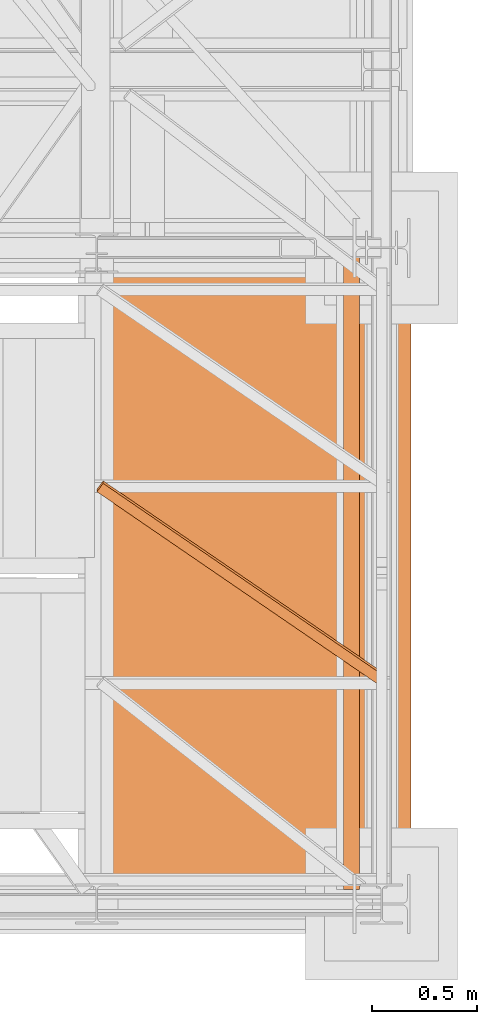
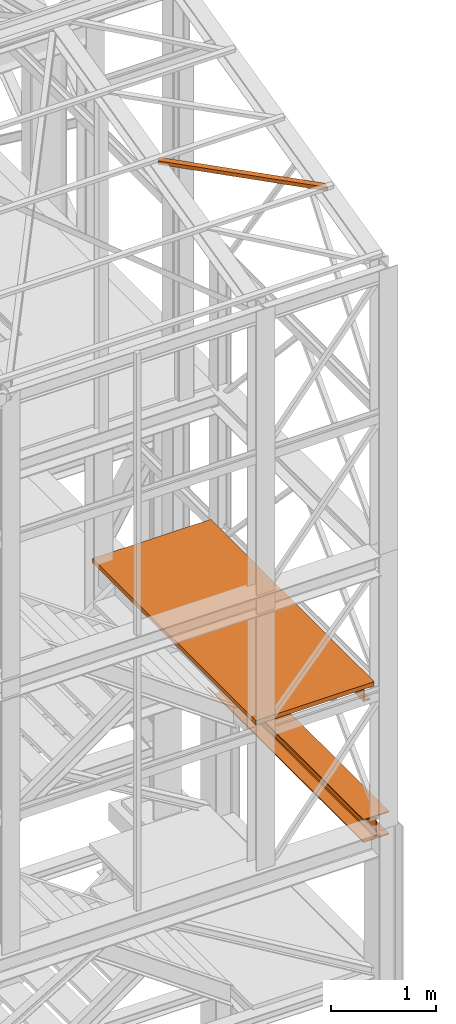
# One storey, part 51 of 208: 4 proxies.
"""IFC2X3 building model written with IfcOpenShell, lengths in millimetres."""

from ifc_helpers import new_model, entity, si_unit, converted_unit, frame, origin, origin_with_axes, place, context, subcontext, project, spatial, faceted_brep, element, save


model = new_model("IFC2X3")

# Units and contexts
model_context = context("Model", 3, precision=1e-05, world=origin())
plan_context = context("Plan", 3, precision=1e-05, world=origin())
body_context = subcontext(model_context, "Body", "Model", "MODEL_VIEW")
ifc_project = project(units=[si_unit("LENGTHUNIT", "METRE", prefix="MILLI"), converted_unit("PLANEANGLEUNIT", "DEGREE", entity("IfcPlaneAngleMeasure", 0.0174532925199433), si_unit("PLANEANGLEUNIT", "RADIAN"), dimensions=[0, 0, 0, 0, 0, 0, 0]), si_unit("AREAUNIT", "SQUARE_METRE"), si_unit("VOLUMEUNIT", "CUBIC_METRE")], contexts=[model_context, plan_context])

# Building, storey
building_placement = place(None, origin())
building = spatial("IfcBuilding", under=ifc_project, at=building_placement, CompositionType="COMPLEX")
storey_placement = place(building_placement, origin_with_axes())
storey = spatial("IfcBuildingStorey", under=building, at=storey_placement, Name="Geschoss", CompositionType="ELEMENT")

# Proxies
proxy_1_placement = place(storey_placement, frame((6558.254967932618, -25032.57438972184, 5014.98999463558), z_axis=(0.0, 0.0, 1.0), x_axis=(1.0, 0.0, 0.0)))
element("IfcBuildingElementProxy", 1, at=proxy_1_placement, inside=storey, context=body_context, shape_type="Brep", body=[
    faceted_brep([(280.0100011920949, 3110.009999999998, 270.0100107288363), (275.0100059604665, 3110.009999999998, 270.0100107288363), (275.0100059604665, 3110.009999999998, 257.0100141859057), (280.0100011920949, 3110.009999999998, 257.0100141859057), (275.0100059604665, 3110.009999999998, 13.00999654293082), (275.0100059604665, 3110.009999999998, 0.01000000000021828), (280.0100011920949, 3110.009999999998, 0.01000000000021828), (280.0100011920949, 3110.009999999998, 13.00999654293082), (5.009995231631365, 2970.009999403952, 257.0100141859057), (5.009995231631365, 2970.009999403952, 270.0100107288363), (0.01000000000112777, 2970.009999403952, 270.0100107288363), (0.01000000000112777, 2970.009999403952, 257.0100141859057), (5.009995231631365, 2970.009999403952, 13.00999654293082), (0.01000000000112777, 2970.009999403952, 13.00999654293082), (0.01000000000112777, 2970.009999403952, 0.01000000000021828), (5.009995231631365, 2970.009999403952, 0.01000000000021828), (0.01000000000112777, 2970.009999403952, 270.0100107288363), (5.009995231631365, 2970.009999403952, 270.0100107288363), (5.009995231631365, 2830.009998807906, 270.0100107288354), (275.0100059604665, 2830.009998807906, 270.0100107288354), (275.0100059604665, 3110.009999999998, 270.0100107288363), (280.0100011920949, 3110.009999999998, 270.0100107288363), (280.0100011920949, 0.00999999999839929, 270.0100107288354), (0.01000000000021828, 0.00999999999839929, 270.0100107288354), (0.01000000000112777, 2970.009999403952, 257.0100141859057), (0.01000000000112777, 2970.009999403952, 270.0100107288363), (0.01000000000021828, 0.00999999999839929, 270.0100107288354), (0.01000000000021828, 0.01000000000203727, 257.0100141859048), (5.009995231631365, 2970.009999403952, 257.0100141859057), (0.01000000000112777, 2970.009999403952, 257.0100141859057), (0.01000000000021828, 0.01000000000203727, 257.0100141859048), (112.0099997317793, 0.01000000000203727, 257.0100141859039), (112.0099997317802, 2830.009998807906, 257.0100141859057), (5.009995231631365, 2830.009998807906, 257.0100141859057), (112.0099997317802, 2830.009998807906, 257.0100141859057), (112.0099997317793, 0.01000000000203727, 257.0100141859039), (124.4310805743935, 0.00999999999839929, 254.5239491558077), (124.4310805743944, 2830.009998807906, 254.5239491558077), (124.4310805743944, 2830.009998807906, 254.5239491558077), (124.4310805743935, 0.00999999999839929, 254.5239491558077), (133.5239363072815, 0.00999999999839929, 245.4310892319681), (133.5239363072824, 2830.009998807906, 245.4310892319681), (133.5239363072824, 2830.009998807906, 245.4310892319681), (133.5239363072815, 0.00999999999839929, 245.4310892319681), (136.0100004060569, 0.00999999999839929, 233.0100102519982), (136.0100004060578, 2830.009998807906, 233.0100102519991), (136.0100004060578, 2830.009998807906, 233.0100102519991), (136.0100004060569, 0.00999999999839929, 233.0100102519982), (136.0100004060569, 0.00999999999839929, 37.01000047683738), (136.0100004060578, 2830.009998807906, 37.01000047683738), (136.0100004060578, 2830.009998807906, 37.01000047683738), (136.0100004060569, 0.00999999999839929, 37.01000047683738), (133.5239363072815, 0.00999999999839929, 24.58892149686835), (133.5239363072824, 2830.009998807906, 24.58892149686835), (133.5239363072824, 2830.009998807906, 24.58892149686835), (133.5239363072815, 0.00999999999839929, 24.58892149686835), (124.4310805743935, 0.01000000000203727, 15.49606157302878), (124.4310805743944, 2830.009998807906, 15.49606157302878), (124.4310805743944, 2830.009998807906, 15.49606157302878), (124.4310805743935, 0.01000000000203727, 15.49606157302878), (112.0099997317793, 0.00999999999839929, 13.00999654293082), (112.0099997317802, 2830.009998807906, 13.00999654293082), (0.01000000000112777, 2970.009999403952, 13.00999654293082), (5.009995231631365, 2970.009999403952, 13.00999654293082), (5.009995231631365, 2830.009998807906, 13.00999654293082), (112.0099997317802, 2830.009998807906, 13.00999654293082), (112.0099997317793, 0.00999999999839929, 13.00999654293082), (0.01000000000021828, 0.00999999999839929, 13.00999654293082), (0.01000000000112777, 2970.009999403952, 0.01000000000021828), (0.01000000000112777, 2970.009999403952, 13.00999654293082), (0.01000000000021828, 0.00999999999839929, 13.00999654293082), (0.01000000000021828, 0.01000000000203727, 0.01000000000021828), (280.0100011920949, 3110.009999999998, 0.01000000000021828), (275.0100059604665, 3110.009999999998, 0.01000000000021828), (275.0100059604665, 2830.009998807906, 0.01000000000021828), (5.009995231631365, 2830.009998807906, 0.01000000000021828), (5.009995231631365, 2970.009999403952, 0.01000000000021828), (0.01000000000112777, 2970.009999403952, 0.01000000000021828), (0.01000000000021828, 0.01000000000203727, 0.01000000000021828), (280.0100011920949, 0.00999999999839929, 0.01000000000021828), (280.0100011920949, 3110.009999999998, 13.00999654293082), (280.0100011920949, 3110.009999999998, 0.01000000000021828), (280.0100011920949, 0.00999999999839929, 0.01000000000021828), (280.0100011920949, 0.00999999999839929, 13.00999654293082), (275.0100059604665, 3110.009999999998, 13.00999654293082), (280.0100011920949, 3110.009999999998, 13.00999654293082), (280.0100011920949, 0.00999999999839929, 13.00999654293082), (168.010001460314, 0.00999999999839929, 13.00999654293082), (168.0100014603149, 2830.009998807906, 13.00999654293082), (275.0100059604665, 2830.009998807906, 13.00999654293082), (168.0100014603149, 2830.009998807906, 13.00999654293082), (168.010001460314, 0.00999999999839929, 13.00999654293082), (155.5889206176998, 0.00999999999839929, 15.49606157302878), (155.5889206177008, 2830.009998807906, 15.49606157302878), (155.5889206177008, 2830.009998807906, 15.49606157302878), (155.5889206176998, 0.00999999999839929, 15.49606157302878), (146.4960648848119, 0.01000000000203727, 24.58892149686835), (146.4960648848128, 2830.009998807906, 24.58892149686835), (146.4960648848128, 2830.009998807906, 24.58892149686835), (146.4960648848119, 0.01000000000203727, 24.58892149686835), (144.0100007860365, 0.00999999999839929, 37.01000047683647), (144.0100007860374, 2830.009998807906, 37.01000047683738), (144.0100007860374, 2830.009998807906, 37.01000047683738), (144.0100007860365, 0.00999999999839929, 37.01000047683647), (144.0100007860365, 0.00999999999839929, 233.0100102519982), (144.0100007860374, 2830.009998807906, 233.0100102519991), (144.0100007860374, 2830.009998807906, 233.0100102519991), (144.0100007860365, 0.00999999999839929, 233.0100102519982), (146.4960648848119, 0.01000000000203727, 245.4310892319663), (146.4960648848128, 2830.009998807906, 245.4310892319681), (146.4960648848128, 2830.009998807906, 245.4310892319681), (146.4960648848119, 0.01000000000203727, 245.4310892319663), (155.5889206176998, 0.01000000000203727, 254.5239491558068), (155.5889206177008, 2830.009998807906, 254.5239491558077), (155.5889206177008, 2830.009998807906, 254.5239491558077), (155.5889206176998, 0.01000000000203727, 254.5239491558068), (168.010001460314, 0.00999999999839929, 257.0100141859048), (168.0100014603149, 2830.009998807906, 257.0100141859057), (280.0100011920949, 3110.009999999998, 257.0100141859057), (275.0100059604665, 3110.009999999998, 257.0100141859057), (275.0100059604665, 2830.009998807906, 257.0100141859048), (168.0100014603149, 2830.009998807906, 257.0100141859057), (168.010001460314, 0.00999999999839929, 257.0100141859048), (280.0100011920949, 0.00999999999839929, 257.0100141859048), (280.0100011920949, 3110.009999999998, 270.0100107288363), (280.0100011920949, 3110.009999999998, 257.0100141859057), (280.0100011920949, 0.00999999999839929, 257.0100141859048), (280.0100011920949, 0.00999999999839929, 270.0100107288354), (280.0100011920949, 0.00999999999839929, 0.01000000000021828), (0.01000000000021828, 0.01000000000203727, 0.01000000000021828), (0.01000000000021828, 0.00999999999839929, 13.00999654293082), (112.0099997317793, 0.00999999999839929, 13.00999654293082), (124.4310805743935, 0.01000000000203727, 15.49606157302878), (133.5239363072815, 0.00999999999839929, 24.58892149686835), (136.0100004060569, 0.00999999999839929, 37.01000047683738), (136.0100004060569, 0.00999999999839929, 233.0100102519982), (133.5239363072815, 0.00999999999839929, 245.4310892319681), (124.4310805743935, 0.00999999999839929, 254.5239491558077), (112.0099997317793, 0.01000000000203727, 257.0100141859039), (0.01000000000021828, 0.01000000000203727, 257.0100141859048), (0.01000000000021828, 0.00999999999839929, 270.0100107288354), (280.0100011920949, 0.00999999999839929, 270.0100107288354), (280.0100011920949, 0.00999999999839929, 257.0100141859048), (168.010001460314, 0.00999999999839929, 257.0100141859048), (155.5889206176998, 0.01000000000203727, 254.5239491558068), (146.4960648848119, 0.01000000000203727, 245.4310892319663), (144.0100007860365, 0.00999999999839929, 233.0100102519982), (144.0100007860365, 0.00999999999839929, 37.01000047683647), (146.4960648848119, 0.01000000000203727, 24.58892149686835), (155.5889206176998, 0.00999999999839929, 15.49606157302878), (168.010001460314, 0.00999999999839929, 13.00999654293082), (280.0100011920949, 0.00999999999839929, 13.00999654293082), (5.009995231631365, 2830.009998807906, 0.01000000000021828), (275.0100059604665, 2830.009998807906, 0.01000000000021828), (275.0100059604665, 2830.009998807906, 13.00999654293082), (168.0100014603149, 2830.009998807906, 13.00999654293082), (155.5889206177008, 2830.009998807906, 15.49606157302878), (146.4960648848128, 2830.009998807906, 24.58892149686835), (144.0100007860374, 2830.009998807906, 37.01000047683738), (144.0100007860374, 2830.009998807906, 233.0100102519991), (146.4960648848128, 2830.009998807906, 245.4310892319681), (155.5889206177008, 2830.009998807906, 254.5239491558077), (168.0100014603149, 2830.009998807906, 257.0100141859057), (275.0100059604665, 2830.009998807906, 257.0100141859048), (275.0100059604665, 2830.009998807906, 270.0100107288354), (5.009995231631365, 2830.009998807906, 270.0100107288354), (5.009995231631365, 2830.009998807906, 257.0100141859057), (112.0099997317802, 2830.009998807906, 257.0100141859057), (124.4310805743944, 2830.009998807906, 254.5239491558077), (133.5239363072824, 2830.009998807906, 245.4310892319681), (136.0100004060578, 2830.009998807906, 233.0100102519991), (136.0100004060578, 2830.009998807906, 37.01000047683738), (133.5239363072824, 2830.009998807906, 24.58892149686835), (124.4310805743944, 2830.009998807906, 15.49606157302878), (112.0099997317802, 2830.009998807906, 13.00999654293082), (5.009995231631365, 2830.009998807906, 13.00999654293082), (275.0100059604665, 2830.009998807906, 257.0100141859048), (275.0100059604665, 3110.009999999998, 257.0100141859057), (275.0100059604665, 3110.009999999998, 270.0100107288363), (275.0100059604665, 2830.009998807906, 270.0100107288354), (275.0100059604665, 2830.009998807906, 0.01000000000021828), (275.0100059604665, 3110.009999999998, 0.01000000000021828), (275.0100059604665, 3110.009999999998, 13.00999654293082), (275.0100059604665, 2830.009998807906, 13.00999654293082), (5.009995231631365, 2830.009998807906, 13.00999654293082), (5.009995231631365, 2970.009999403952, 13.00999654293082), (5.009995231631365, 2970.009999403952, 0.01000000000021828), (5.009995231631365, 2830.009998807906, 0.01000000000021828), (5.009995231631365, 2830.009998807906, 270.0100107288354), (5.009995231631365, 2970.009999403952, 270.0100107288363), (5.009995231631365, 2970.009999403952, 257.0100141859057), (5.009995231631365, 2830.009998807906, 257.0100141859057)], [[[0, 1, 2, 3]], [[4, 5, 6, 7]], [[8, 9, 10, 11]], [[12, 13, 14, 15]], [[16, 17, 18, 19, 20, 21, 22, 23]], [[24, 25, 26, 27]], [[28, 29, 30, 31, 32, 33]], [[34, 35, 36, 37]], [[38, 39, 40, 41]], [[42, 43, 44, 45]], [[46, 47, 48, 49]], [[50, 51, 52, 53]], [[54, 55, 56, 57]], [[58, 59, 60, 61]], [[62, 63, 64, 65, 66, 67]], [[68, 69, 70, 71]], [[72, 73, 74, 75, 76, 77, 78, 79]], [[80, 81, 82, 83]], [[84, 85, 86, 87, 88, 89]], [[90, 91, 92, 93]], [[94, 95, 96, 97]], [[98, 99, 100, 101]], [[102, 103, 104, 105]], [[106, 107, 108, 109]], [[110, 111, 112, 113]], [[114, 115, 116, 117]], [[118, 119, 120, 121, 122, 123]], [[124, 125, 126, 127]], [[128, 129, 130, 131, 132, 133, 134, 135, 136, 137, 138, 139, 140, 141, 142, 143, 144, 145, 146, 147, 148, 149, 150, 151]], [[152, 153, 154, 155, 156, 157, 158, 159, 160, 161, 162, 163, 164, 165, 166, 167, 168, 169, 170, 171, 172, 173, 174, 175]], [[176, 177, 178, 179]], [[180, 181, 182, 183]], [[184, 185, 186, 187]], [[188, 189, 190, 191]]], orient=[[False], [False], [False], [False], [False], [False], [False], [False], [False], [False], [False], [False], [False], [False], [False], [False], [False], [False], [False], [False], [False], [False], [False], [False], [False], [False], [False], [False], [False], [False], [False], [False], [False], [False]]),
])
proxy_2_placement = place(storey_placement, frame((6518.739101185618, -25102.57439001986, 6709.989998509885), z_axis=(0.0, 0.0, 1.0), x_axis=(1.0, 0.0, 0.0)))
element("IfcBuildingElementProxy", 2, at=proxy_2_placement, inside=storey, context=body_context, shape_type="Brep", body=[
    faceted_brep([(0.01000000000021828, 3019.86355885294, 200.0100029802325), (0.01000000000021828, 3019.86355885294, 0.01000000000021828), (75.01000111758731, 3019.86355885294, 0.01000000000021828), (75.01000111758731, 3019.86355885294, 2.97083092689536), (73.89400100171588, 3019.86355885294, 7.368834147453526), (69.48847269475482, 3019.86355885294, 8.951724896431188), (19.09293180167697, 3019.86355885294, 12.98336816787742), (13.35380079060815, 3019.86355885294, 14.57858962774299), (9.50015002697728, 3019.86355885294, 18.85888857603095), (8.510000461936215, 3019.86355885294, 24.44674206733725), (8.510000461936215, 3019.86355885294, 175.5732609128954), (9.50015002697728, 3019.86355885294, 181.1611144042017), (13.35380079060815, 3019.86355885294, 185.4414133524897), (19.09293180167697, 3019.86355885294, 187.0366348123553), (69.48847269475482, 3019.86355885294, 191.0682780838015), (73.89400100171588, 3019.86355885294, 192.6511688327792), (75.01000111758731, 3019.86355885294, 197.0491720533373), (75.01000111758731, 3019.86355885294, 200.0100029802325), (0.01000000000021828, 3019.86355885294, 0.01000000000021828), (0.01000000000021828, 3019.86355885294, 200.0100029802325), (0.01000000000021828, 0.00999999999839929, 200.0100029802325), (0.01000000000021828, 0.00999999999839929, 0.01000000000021828), (75.01000111758731, 3019.86355885294, 0.01000000000021828), (0.01000000000021828, 3019.86355885294, 0.01000000000021828), (0.01000000000021828, 0.00999999999839929, 0.01000000000021828), (75.01000111758731, 0.00999999999839929, 0.01000000000021828), (75.01000111758731, 3019.86355885294, 2.97083092689536), (75.01000111758731, 3019.86355885294, 0.01000000000021828), (75.01000111758731, 0.00999999999839929, 0.01000000000021828), (75.01000111758731, 0.00999999999839929, 2.97083092689536), (73.89400100171588, 3019.86355885294, 7.368834147453526), (75.01000111758731, 3019.86355885294, 2.97083092689536), (75.01000111758731, 0.00999999999839929, 2.97083092689536), (73.89400100171588, 0.00999999999839929, 7.368834147453526), (69.48847269475482, 3019.86355885294, 8.951724896431188), (73.89400100171588, 3019.86355885294, 7.368834147453526), (73.89400100171588, 0.00999999999839929, 7.368834147453526), (69.48847269475482, 0.00999999999839929, 8.951724896431188), (19.09293180167697, 3019.86355885294, 12.98336816787742), (69.48847269475482, 3019.86355885294, 8.951724896431188), (69.48847269475482, 0.00999999999839929, 8.951724896431188), (19.09293180167697, 0.00999999999839929, 12.98336816787742), (13.35380079060815, 3019.86355885294, 14.57858962774299), (19.09293180167697, 3019.86355885294, 12.98336816787742), (19.09293180167697, 0.00999999999839929, 12.98336816787742), (13.35380079060815, 0.00999999999839929, 14.57858962774299), (9.50015002697728, 3019.86355885294, 18.85888857603095), (13.35380079060815, 3019.86355885294, 14.57858962774299), (13.35380079060815, 0.00999999999839929, 14.57858962774299), (9.50015002697728, 0.00999999999839929, 18.85888857603095), (8.510000461936215, 3019.86355885294, 24.44674206733725), (9.50015002697728, 3019.86355885294, 18.85888857603095), (9.50015002697728, 0.00999999999839929, 18.85888857603095), (8.510000461936215, 0.00999999999839929, 24.44674206733725), (8.510000461936215, 3019.86355885294, 175.5732609128954), (8.510000461936215, 3019.86355885294, 24.44674206733725), (8.510000461936215, 0.00999999999839929, 24.44674206733725), (8.510000461936215, 0.00999999999839929, 175.5732609128954), (9.50015002697728, 3019.86355885294, 181.1611144042017), (8.510000461936215, 3019.86355885294, 175.5732609128954), (8.510000461936215, 0.00999999999839929, 175.5732609128954), (9.50015002697728, 0.00999999999839929, 181.1611144042017), (13.35380079060815, 3019.86355885294, 185.4414133524897), (9.50015002697728, 3019.86355885294, 181.1611144042017), (9.50015002697728, 0.00999999999839929, 181.1611144042017), (13.35380079060815, 0.00999999999839929, 185.4414133524897), (19.09293180167697, 3019.86355885294, 187.0366348123553), (13.35380079060815, 3019.86355885294, 185.4414133524897), (13.35380079060815, 0.00999999999839929, 185.4414133524897), (19.09293180167697, 0.00999999999839929, 187.0366348123553), (69.48847269475482, 3019.86355885294, 191.0682780838015), (19.09293180167697, 3019.86355885294, 187.0366348123553), (19.09293180167697, 0.00999999999839929, 187.0366348123553), (69.48847269475482, 0.00999999999839929, 191.0682780838015), (73.89400100171588, 3019.86355885294, 192.6511688327792), (69.48847269475482, 3019.86355885294, 191.0682780838015), (69.48847269475482, 0.00999999999839929, 191.0682780838015), (73.89400100171588, 0.00999999999839929, 192.6511688327792), (75.01000111758731, 3019.86355885294, 197.0491720533373), (73.89400100171588, 3019.86355885294, 192.6511688327792), (73.89400100171588, 0.00999999999839929, 192.6511688327792), (75.01000111758731, 0.00999999999839929, 197.0491720533373), (75.01000111758731, 3019.86355885294, 200.0100029802325), (75.01000111758731, 3019.86355885294, 197.0491720533373), (75.01000111758731, 0.00999999999839929, 197.0491720533373), (75.01000111758731, 0.00999999999839929, 200.0100029802325), (0.01000000000021828, 3019.86355885294, 200.0100029802325), (75.01000111758731, 3019.86355885294, 200.0100029802325), (75.01000111758731, 0.00999999999839929, 200.0100029802325), (0.01000000000021828, 0.00999999999839929, 200.0100029802325), (0.01000000000021828, 0.00999999999839929, 200.0100029802325), (75.01000111758731, 0.00999999999839929, 200.0100029802325), (75.01000111758731, 0.00999999999839929, 197.0491720533373), (73.89400100171588, 0.00999999999839929, 192.6511688327792), (69.48847269475482, 0.00999999999839929, 191.0682780838015), (19.09293180167697, 0.00999999999839929, 187.0366348123553), (13.35380079060815, 0.00999999999839929, 185.4414133524897), (9.50015002697728, 0.00999999999839929, 181.1611144042017), (8.510000461936215, 0.00999999999839929, 175.5732609128954), (8.510000461936215, 0.00999999999839929, 24.44674206733725), (9.50015002697728, 0.00999999999839929, 18.85888857603095), (13.35380079060815, 0.00999999999839929, 14.57858962774299), (19.09293180167697, 0.00999999999839929, 12.98336816787742), (69.48847269475482, 0.00999999999839929, 8.951724896431188), (73.89400100171588, 0.00999999999839929, 7.368834147453526), (75.01000111758731, 0.00999999999839929, 2.97083092689536), (75.01000111758731, 0.00999999999839929, 0.01000000000021828), (0.01000000000021828, 0.00999999999839929, 0.01000000000021828)], [[[0, 1, 2, 3, 4, 5, 6, 7, 8, 9, 10, 11, 12, 13, 14, 15, 16, 17]], [[18, 19, 20, 21]], [[22, 23, 24, 25]], [[26, 27, 28, 29]], [[30, 31, 32, 33]], [[34, 35, 36, 37]], [[38, 39, 40, 41]], [[42, 43, 44, 45]], [[46, 47, 48, 49]], [[50, 51, 52, 53]], [[54, 55, 56, 57]], [[58, 59, 60, 61]], [[62, 63, 64, 65]], [[66, 67, 68, 69]], [[70, 71, 72, 73]], [[74, 75, 76, 77]], [[78, 79, 80, 81]], [[82, 83, 84, 85]], [[86, 87, 88, 89]], [[90, 91, 92, 93, 94, 95, 96, 97, 98, 99, 100, 101, 102, 103, 104, 105, 106, 107]]], orient=[[False], [False], [False], [False], [False], [False], [False], [False], [False], [False], [False], [False], [False], [False], [False], [False], [False], [False], [False], [False]]),
])
proxy_3_placement = place(storey_placement, frame((5293.401408260118, -25172.57439031789, 6909.990001490117), z_axis=(0.0, 0.0, 1.0), x_axis=(1.0, 0.0, 0.0)))
element("IfcBuildingElementProxy", 3, at=proxy_3_placement, inside=storey, context=body_context, shape_type="Brep", body=[
    faceted_brep([(0.009999999999308784, 0.00999999999839929, 0.01000000000021828), (1300.347694043087, 0.00999999999839929, 0.01000000000021828), (1300.347694043088, 3110.009999999998, 0.01000000000021828), (0.009999999999308784, 3110.009999999998, 0.01000000000021828), (1300.347694043087, 0.00999999999839929, 50.01000000000022), (0.009999999999308784, 0.00999999999839929, 50.01000000000022), (0.009999999999308784, 3110.009999999998, 50.01000000000022), (1300.347694043088, 3110.009999999998, 50.01000000000022), (1300.347694043087, 0.00999999999839929, 0.01000000000021828), (0.009999999999308784, 0.00999999999839929, 0.01000000000021828), (0.009999999999308784, 0.00999999999839929, 50.01000000000022), (1300.347694043087, 0.00999999999839929, 50.01000000000022), (1300.347694043088, 3110.009999999998, 0.01000000000021828), (1300.347694043087, 0.00999999999839929, 0.01000000000021828), (1300.347694043087, 0.00999999999839929, 50.01000000000022), (1300.347694043088, 3110.009999999998, 50.01000000000022), (0.009999999999308784, 3110.009999999998, 0.01000000000021828), (1300.347694043088, 3110.009999999998, 0.01000000000021828), (1300.347694043088, 3110.009999999998, 50.01000000000022), (0.009999999999308784, 3110.009999999998, 50.01000000000022), (0.009999999999308784, 0.00999999999839929, 0.01000000000021828), (0.009999999999308784, 3110.009999999998, 0.01000000000021828), (0.009999999999308784, 3110.009999999998, 50.01000000000022), (0.009999999999308784, 0.00999999999839929, 50.01000000000022)], [[[0, 1, 2, 3]], [[4, 5, 6, 7]], [[8, 9, 10, 11]], [[12, 13, 14, 15]], [[16, 17, 18, 19]], [[20, 21, 22, 23]]], orient=[[False], [False], [False], [False], [False], [False]]),
])
proxy_4_placement = place(storey_placement, frame((5349.415251226796, -24134.74431075611, 11987.74979641016), z_axis=(0.0, 0.0, 1.0), x_axis=(1.0, 0.0, 0.0)))
element("IfcBuildingElementProxy", 4, at=proxy_4_placement, inside=storey, context=body_context, shape_type="Brep", body=[
    faceted_brep([(28.82079669527775, 967.7692788621025, 232.0521250666225), (28.82079669527775, 955.9752131652676, 280.6412186405796), (0.01000000000021828, 916.2634686381462, 271.0019582749592), (0.01000000000021828, 928.0575343349847, 222.4128647010039), (1337.349720073478, 71.25499243027298, 14.44056628674844), (1337.349720073478, 59.4609267334381, 63.02965986070558), (28.82079669527775, 955.9752131652676, 280.6412186405796), (28.82079669527775, 967.7692788621025, 232.0521250666225), (1337.349720073478, 11.80406569683692, 0.01000000000021828), (1337.349720073478, 71.25499243027298, 14.44056628674844), (28.82079669527775, 967.7692788621025, 232.0521250666225), (0.01000000000021828, 928.0575343349847, 222.4128647010039), (1337.349720073478, 0.00999999999839929, 48.59909357395554), (1337.349720073478, 11.80406569683692, 0.01000000000021828), (0.01000000000021828, 928.0575343349847, 222.4128647010039), (0.01000000000021828, 916.2634686381462, 271.0019582749592), (1337.349720073478, 59.4609267334381, 63.02965986070558), (1337.349720073478, 0.00999999999839929, 48.59909357395554), (0.01000000000021828, 916.2634686381462, 271.0019582749592), (28.82079669527775, 955.9752131652676, 280.6412186405796), (1337.349720073478, 71.25499243027298, 14.44056628674844), (1337.349720073478, 11.80406569683692, 0.01000000000021828), (1337.349720073478, 0.00999999999839929, 48.59909357395554), (1337.349720073478, 59.4609267334381, 63.02965986070558)], [[[0, 1, 2, 3]], [[4, 5, 6, 7]], [[8, 9, 10, 11]], [[12, 13, 14, 15]], [[16, 17, 18, 19]], [[20, 21, 22, 23]]], orient=[[False], [False], [False], [False], [False], [False]]),
])

save(model, "model.ifc")
